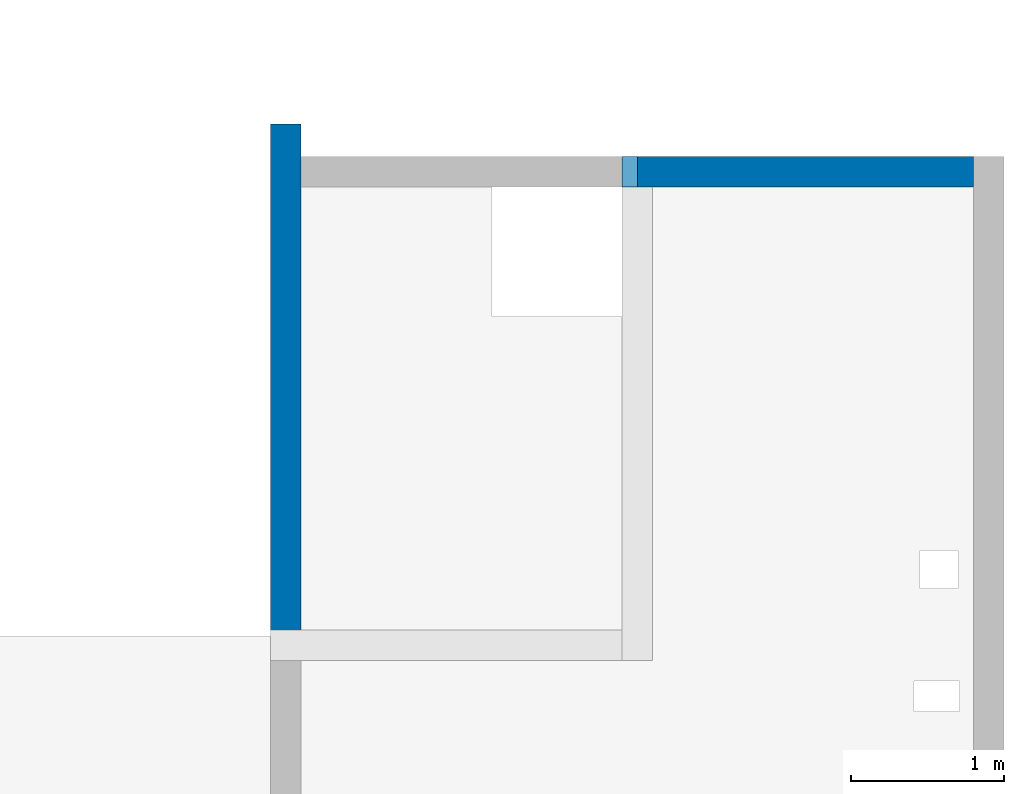
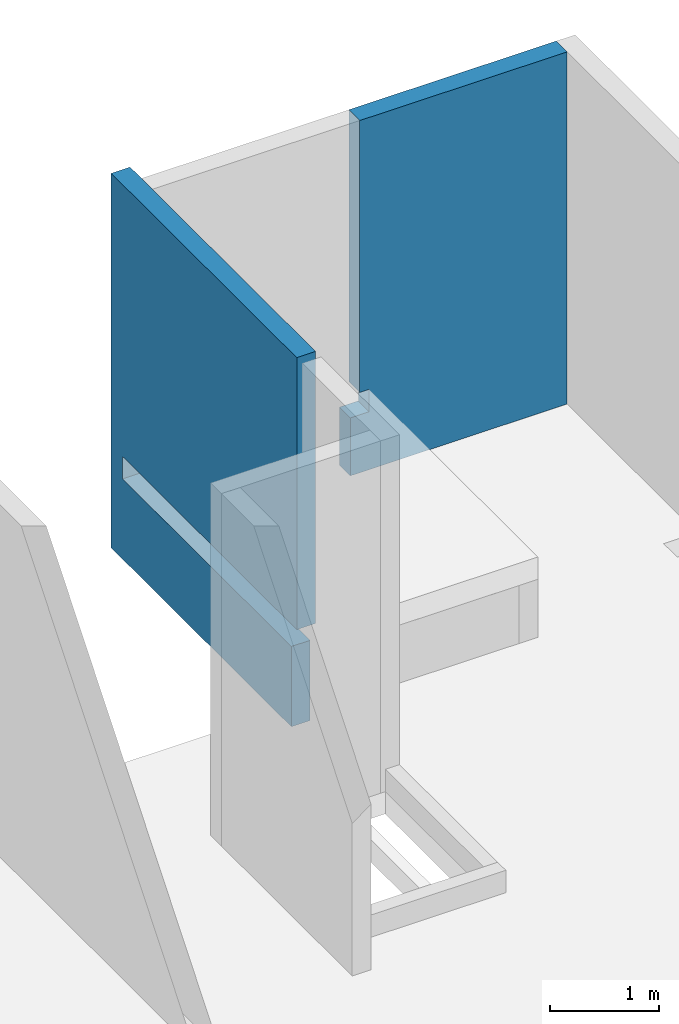
# One storey, part 6 of 6: 2 walls.
"""IFC4 building model written with IfcOpenShell, lengths in millimetres."""

from ifc_helpers import new_model, entity, si_unit, converted_unit, derived_unit, direction, frame, origin, place, context, subcontext, project, spatial, polygons, material, type_object, element, save


model = new_model("IFC4")

# Units and contexts
model_context = context("Model", 3, precision=0.01, world=origin(), true_north=direction((6.12303176911189e-17, 1.0)))
plan_context = context("Plan", 3, precision=0.01, world=origin(), true_north=direction((6.12303176911189e-17, 1.0)))
body_context = subcontext(model_context, "Body", "Model", "MODEL_VIEW")
ifc_project = project(units=[si_unit("LENGTHUNIT", "METRE", prefix="MILLI"), si_unit("AREAUNIT", "SQUARE_METRE"), si_unit("VOLUMEUNIT", "CUBIC_METRE"), converted_unit("PLANEANGLEUNIT", "DEGREE", entity("IfcRatioMeasure", 0.0174532925199433), si_unit("PLANEANGLEUNIT", "RADIAN"), dimensions=[0, 0, 0, 0, 0, 0, 0]), si_unit("MASSUNIT", "GRAM", prefix="KILO"), derived_unit("MASSDENSITYUNIT", [(si_unit("MASSUNIT", "GRAM", prefix="KILO"), 1), (si_unit("LENGTHUNIT", "METRE"), -3)]), derived_unit("MOMENTOFINERTIAUNIT", [(si_unit("LENGTHUNIT", "METRE"), 4)]), si_unit("TIMEUNIT", "SECOND"), si_unit("FREQUENCYUNIT", "HERTZ"), si_unit("THERMODYNAMICTEMPERATUREUNIT", "DEGREE_CELSIUS"), derived_unit("THERMALTRANSMITTANCEUNIT", [(si_unit("MASSUNIT", "GRAM", prefix="KILO"), 1), (si_unit("THERMODYNAMICTEMPERATUREUNIT", "KELVIN"), -1), (si_unit("TIMEUNIT", "SECOND"), -3)]), derived_unit("VOLUMETRICFLOWRATEUNIT", [(si_unit("LENGTHUNIT", "METRE"), 3), (si_unit("TIMEUNIT", "SECOND"), -1)]), derived_unit("MASSFLOWRATEUNIT", [(si_unit("MASSUNIT", "GRAM", prefix="KILO"), 1), (si_unit("TIMEUNIT", "SECOND"), -1)]), derived_unit("ROTATIONALFREQUENCYUNIT", [(si_unit("TIMEUNIT", "SECOND"), -1)]), si_unit("ELECTRICCURRENTUNIT", "AMPERE"), si_unit("ELECTRICVOLTAGEUNIT", "VOLT"), si_unit("POWERUNIT", "WATT"), si_unit("FORCEUNIT", "NEWTON", prefix="KILO"), si_unit("ILLUMINANCEUNIT", "LUX"), si_unit("LUMINOUSFLUXUNIT", "LUMEN"), si_unit("LUMINOUSINTENSITYUNIT", "CANDELA"), derived_unit("USERDEFINED", [(si_unit("MASSUNIT", "GRAM", prefix="KILO"), -1), (si_unit("LENGTHUNIT", "METRE"), -2), (si_unit("TIMEUNIT", "SECOND"), 3), (si_unit("LUMINOUSFLUXUNIT", "LUMEN"), 1)]), derived_unit("LINEARVELOCITYUNIT", [(si_unit("LENGTHUNIT", "METRE"), 1), (si_unit("TIMEUNIT", "SECOND"), -1)]), si_unit("PRESSUREUNIT", "PASCAL"), derived_unit("USERDEFINED", [(si_unit("LENGTHUNIT", "METRE"), -2), (si_unit("MASSUNIT", "GRAM", prefix="KILO"), 1), (si_unit("TIMEUNIT", "SECOND"), -2)]), derived_unit("LINEARFORCEUNIT", [(si_unit("MASSUNIT", "GRAM", prefix="KILO"), 1), (si_unit("LENGTHUNIT", "METRE"), 1), (si_unit("TIMEUNIT", "SECOND"), -2), (si_unit("LENGTHUNIT", "METRE"), -1)]), derived_unit("PLANARFORCEUNIT", [(si_unit("MASSUNIT", "GRAM", prefix="KILO"), 1), (si_unit("LENGTHUNIT", "METRE"), 1), (si_unit("TIMEUNIT", "SECOND"), -2), (si_unit("LENGTHUNIT", "METRE"), -2)])], contexts=[model_context, plan_context])

# Site, building, storey
site_placement = place(None, origin())
site = spatial("IfcSite", under=ifc_project, at=site_placement, CompositionType="ELEMENT")
building_placement = place(site_placement, origin())
building = spatial("IfcBuilding", under=site, at=building_placement, CompositionType="ELEMENT")
storey_placement = place(building_placement, frame((0.0, 0.0, 28200.0)))
storey = spatial("IfcBuildingStorey", under=building, at=storey_placement, Name="08", CompositionType="ELEMENT", Elevation=28200.0)

# Walls
ifc_material = material()
wall_type = type_object("IfcWallType", Name=":ADSK_ 25_200", PredefinedType="STANDARD")
wall_1_placement = place(storey_placement, frame((73370.0, 17470.0, -150.0), z_axis=(0.0, 0.0, 1.0), x_axis=(-1.0, 0.0, 0.0)))
element("IfcWall", 1, at=wall_1_placement, inside=storey, type_object=wall_type, material=ifc_material, Name=":ADSK_ 25_200", ObjectType=":ADSK_ 25_200", PredefinedType="NOTDEFINED", context=body_context, shape_type="Tessellation", body=[
    polygons([(-8.42037747823843e-12, -100.000000000001, 0.0), (2300.00000000001, -100.000000000003, 0.0), (2300.00000000001, -100.000000000003, 650.000000000004), (2100.00000000003, -99.9999999999989, 650.000000000004), (2100.00000000003, -99.9999999999989, 899.999999999999), (2200.00000000001, -100.000000000003, 899.999999999999), (2200.00000000001, -100.000000000003, 3950.0), (-8.42037747823843e-12, -100.000000000001, 3950.0), (2300.00000000001, 99.9999999999968, 0.0), (2100.00000000001, 99.9999999999968, 0.0), (-9.11341244098939e-12, 99.9999999999989, 0.0), (-9.11341244098939e-12, 99.9999999999989, 3950.0), (2200.00000000001, 99.9999999999968, 3950.0), (2200.00000000001, 99.9999999999968, 899.999999999999), (2100.00000000002, 99.9999999999968, 899.999999999999), (2100.00000000002, 99.9999999999968, 650.000000000004), (2300.00000000001, 99.9999999999968, 650.000000000004)], [[[1, 2, 3, 4, 5, 6, 7, 8]], [[9, 10, 11, 12, 13, 14, 15, 16, 17]], [[2, 1, 11, 10, 9]], [[8, 7, 13, 12]], [[1, 8, 12, 11]], [[5, 15, 14, 6]], [[4, 16, 15, 5]], [[13, 7, 6, 14]], [[3, 17, 16, 4]], [[2, 9, 17, 3]]], closed=True),
])
wall_2_placement = place(storey_placement, frame((68870.0, 17780.0, -400.0), z_axis=(0.0, 0.0, 1.0), x_axis=(0.0, -1.0, 0.0)))
element("IfcWall", 2, at=wall_2_placement, inside=storey, type_object=wall_type, material=ifc_material, Name=":ADSK_ 25_200", ObjectType=":ADSK_ 25_200", PredefinedType="NOTDEFINED", context=body_context, shape_type="Tessellation", body=[
    polygons([(2.16573425859679e-12, -99.9999999999978, 0.0), (3310.0, -99.9999999999978, 0.0), (3310.0, -99.9999999999978, 249.999999999999), (3310.0, -99.9999999999978, 900.000000000003), (210.000000000024, -100.000000000006, 900.000000000003), (210.000000000024, -100.000000000006, 1150.0), (3410.0, -99.9999999999976, 1150.0), (3410.0, -99.9999999999976, 4200.0), (3349.99999999998, -99.9999999999977, 4200.0), (210.000000000004, -99.9999999999973, 4200.0), (2.16573425859679e-12, -99.9999999999978, 4200.0), (3310.0, 100.0, 0.0), (410.0, 100.000000000001, 0.0), (210.0, 100.000000000001, 0.0), (2.16573425859679e-12, 100.000000000009, 0.0), (2.16573425859679e-12, 100.000000000009, 4200.0), (210.0, 100.000000000001, 4200.0), (410.0, 100.000000000001, 4200.0), (3410.0, 100.0, 4200.0), (3410.0, 100.0, 1150.0), (410.0, 100.000000000001, 1150.0), (210.000000000024, 100.000000000009, 1150.0), (210.000000000024, 100.000000000009, 900.000000000003), (410.0, 100.000000000001, 899.999999999999), (3310.0, 100.0, 900.000000000003)], [[[1, 2, 3, 4, 5, 6, 7, 8, 9, 10, 11]], [[12, 13, 14, 15, 16, 17, 18, 19, 20, 21, 22, 23, 24, 25]], [[2, 1, 15, 14, 13, 12]], [[11, 10, 9, 8, 19, 18, 17, 16]], [[1, 11, 16, 15]], [[23, 5, 4, 25, 24]], [[6, 22, 21, 20, 7]], [[5, 23, 22, 6]], [[19, 8, 7, 20]], [[2, 12, 25, 4, 3]]], closed=True),
])

save(model, "model.ifc")
